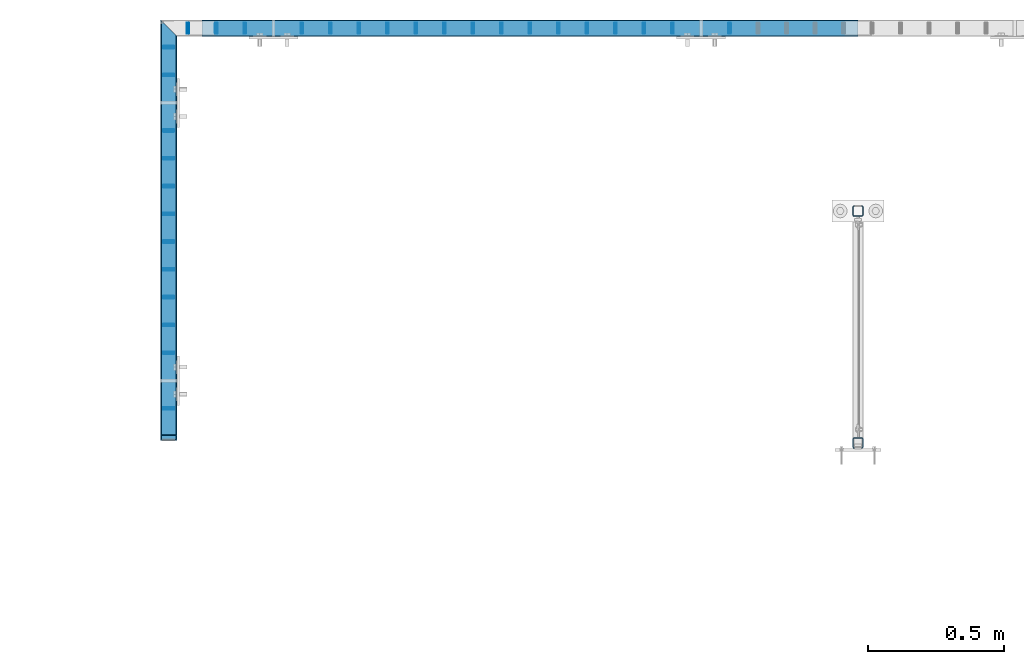
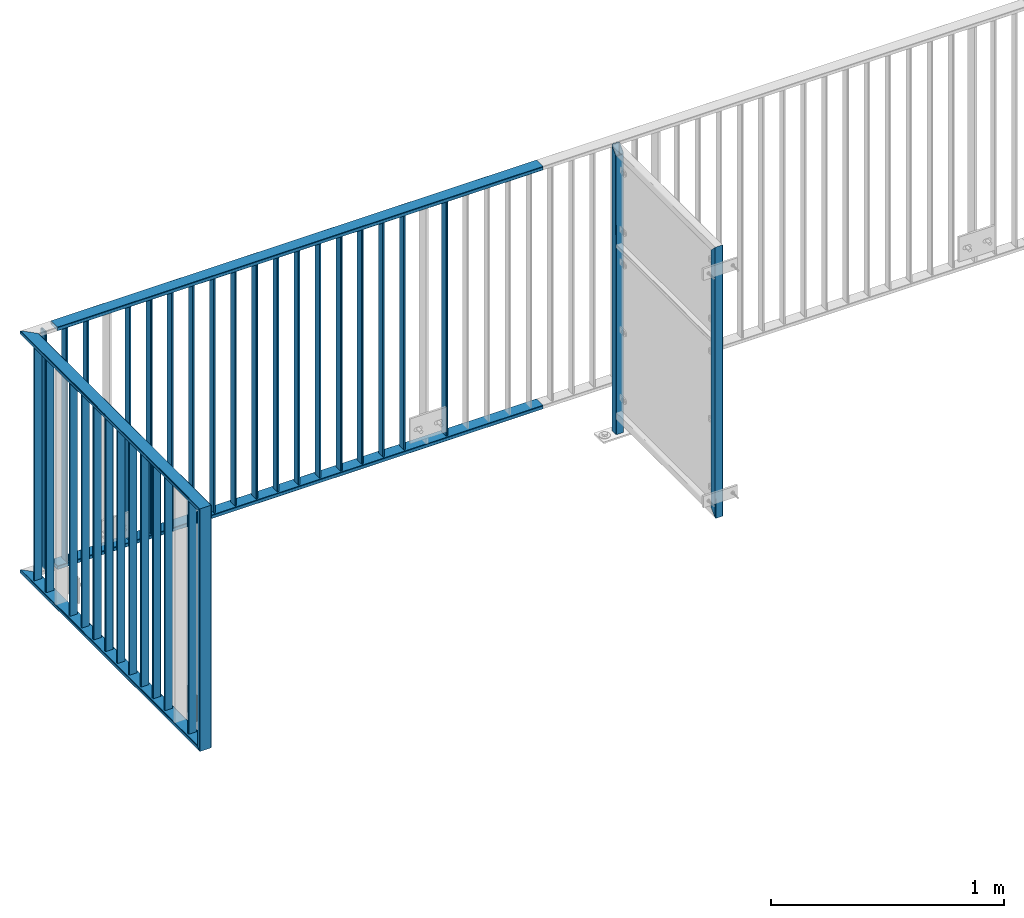
# One storey, part 11 of 156: 37 beams, 3 elements without a shape of their own.
"""IFC2X3 building model written with IfcOpenShell, lengths in millimetres."""

from ifc_helpers import new_model, si_unit, frame, origin_with_axes, origin_2d_with_axis, place, context, subcontext, project, spatial, hollow_rectangle, extrude, clip, halfspace, material, type_object, element, aggregate, save


model = new_model("IFC2X3")

# Units and contexts
model_context = context("Model", 3, precision=1e-05, world=origin_with_axes())
body_context = subcontext(model_context, "Body", "Model", "MODEL_VIEW")
ifc_project = project(units=[si_unit("LENGTHUNIT", "METRE", prefix="MILLI"), si_unit("AREAUNIT", "SQUARE_METRE"), si_unit("VOLUMEUNIT", "CUBIC_METRE"), si_unit("MASSUNIT", "GRAM", prefix="KILO"), si_unit("TIMEUNIT", "SECOND"), si_unit("PLANEANGLEUNIT", "RADIAN"), si_unit("SOLIDANGLEUNIT", "STERADIAN"), si_unit("THERMODYNAMICTEMPERATUREUNIT", "DEGREE_CELSIUS"), si_unit("LUMINOUSINTENSITYUNIT", "LUMEN")], contexts=[model_context])

# Site, building, storey
site_placement = place(None, origin_with_axes())
site = spatial("IfcSite", under=ifc_project, at=site_placement, CompositionType="ELEMENT")
building_placement = place(site_placement, origin_with_axes())
building = spatial("IfcBuilding", under=site, at=building_placement, Name="Undefined", CompositionType="ELEMENT")
storey_placement = place(building_placement, origin_with_axes())
storey = spatial("IfcBuildingStorey", under=building, at=storey_placement, Name="Undefined", CompositionType="ELEMENT", Elevation=0.0)

# Assembly, beam
assembly_1_placement = place(storey_placement, origin_with_axes())
assembly_1 = element("IfcElementAssembly", 1, at=assembly_1_placement, inside=storey, AssemblyPlace="NOTDEFINED", PredefinedType="RIGID_FRAME")
ifc_material = material(Name="STEEL/S235JR")
beam_type_1 = type_object("IfcBeamType", Name="K60/20/2", PredefinedType="NOTDEFINED")
beam_1_placement = place(assembly_1_placement, frame((14799.9535961914, 24057.9916132584, 2740.0), z_axis=(0.0, -1.0, 0.0), x_axis=(-1.0, 0.0, 0.0)))
beam_1 = element("IfcBeam", 2, at=beam_1_placement, type_object=beam_type_1, material=ifc_material, ObjectType="K60/20/2", context=body_context, shape_type="SweptSolid", body=[
    extrude(hollow_rectangle(XDim=20.0, YDim=60.0, WallThickness=2.0, InnerFilletRadius=2.0, OuterFilletRadius=4.0, at=origin_2d_with_axis()), frame((2402.81, 0.0, 0.0), z_axis=(-1.0, 0.0, 0.0), x_axis=(0.0, -1.0, 0.0)), (0.0, 0.0, 1.0), 2402.81),
])

# Assembly, beams
assembly_2_placement = place(storey_placement, origin_with_axes())
assembly_2 = element("IfcElementAssembly", 3, at=assembly_2_placement, inside=storey, AssemblyPlace="NOTDEFINED", PredefinedType="RIGID_FRAME")
beam_2_placement = place(assembly_2_placement, frame((12275.0005187988, 22558.0012658527, 4000.0), z_axis=(1.0, 0.0, 0.0), x_axis=(0.0, 0.0, -1.0)))
beam_2 = element("IfcBeam", 4, at=beam_2_placement, type_object=beam_type_1, material=ifc_material, ObjectType="K60/20/2", context=body_context, shape_type="Clipping", body=[
    clip(clip(extrude(hollow_rectangle(XDim=20.0, YDim=60.0, WallThickness=2.0, InnerFilletRadius=2.0, OuterFilletRadius=4.0, at=origin_2d_with_axis()), frame((1280.2, 0.0, 0.0), z_axis=(-1.0, 0.0, 0.0), x_axis=(0.0, -1.0, 0.0)), (0.0, 0.0, 1.0), 1290.4), halfspace(frame((1270.0, -10.0, 0.0), z_axis=(0.707106781186548, 0.707106781186548, 0.0), x_axis=(0.0, 0.0, 1.0)), False)), halfspace(frame((20.0, 10.0, 0.0), z_axis=(-0.707106781186548, 0.707106781186548, 0.0), x_axis=(0.0, 0.0, 1.0)), False)),
])
beam_3_placement = place(assembly_2_placement, frame((12274.9983520508, 24031.4403835157, 2740.0), z_axis=(1.0, 0.0, 0.0), x_axis=(0.0, -1.0, 0.0)))
beam_3 = element("IfcBeam", 5, at=beam_3_placement, type_object=beam_type_1, material=ifc_material, ObjectType="K60/20/2", context=body_context, shape_type="Clipping", body=[
    clip(clip(extrude(hollow_rectangle(XDim=20.0, YDim=60.0, WallThickness=2.0, InnerFilletRadius=2.0, OuterFilletRadius=4.0, at=origin_2d_with_axis()), frame((1513.83911766303, 0.0, 0.0), z_axis=(-1.0, 0.0, 0.0), x_axis=(0.0, -1.0, 0.0)), (0.0, 0.0, 1.0), 1580.79), halfspace(frame((1483.43911766303, 10.0, 0.002166748046875), z_axis=(-0.707106781186548, 0.707106781186548, 0.0), x_axis=(0.0, 0.0, 1.0)), True)), halfspace(frame((3.44877025730966, 0.0, 30.0), z_axis=(-0.707106781186548, 0.0, 0.707106781186548), x_axis=(0.0, -1.0, 0.0)), False)),
])

# Beam
beam_4_placement = place(assembly_1_placement, frame((14799.9535961914, 24057.9916132584, 3990.0), z_axis=(0.0, -1.0, 0.0), x_axis=(-1.0, 0.0, 0.0)))
beam_4 = element("IfcBeam", 6, at=beam_4_placement, type_object=beam_type_1, material=ifc_material, ObjectType="K60/20/2", context=body_context, shape_type="SweptSolid", body=[
    extrude(hollow_rectangle(XDim=20.0, YDim=60.0, WallThickness=2.0, InnerFilletRadius=2.0, OuterFilletRadius=4.0, at=origin_2d_with_axis()), frame((2402.81, 0.0, 0.0), z_axis=(-1.0, 0.0, 0.0), x_axis=(0.0, -1.0, 0.0)), (0.0, 0.0, 1.0), 2402.81),
])

beam_5_placement = place(assembly_2_placement, frame((12274.9983520508, 24031.4403835157, 3990.0), z_axis=(1.0, 0.0, 0.0), x_axis=(0.0, -1.0, 0.0)))
beam_5 = element("IfcBeam", 7, at=beam_5_placement, type_object=beam_type_1, material=ifc_material, ObjectType="K60/20/2", context=body_context, shape_type="Clipping", body=[
    clip(clip(extrude(hollow_rectangle(XDim=20.0, YDim=60.0, WallThickness=2.0, InnerFilletRadius=2.0, OuterFilletRadius=4.0, at=origin_2d_with_axis()), frame((1513.83911766303, 0.0, 0.0), z_axis=(-1.0, 0.0, 0.0), x_axis=(0.0, -1.0, 0.0)), (0.0, 0.0, 1.0), 1580.79), halfspace(frame((1463.43911766303, 10.0, 0.002166748046875), z_axis=(-0.707106781186548, -0.707106781186548, 0.0), x_axis=(0.0, 0.0, 1.0)), True)), halfspace(frame((-56.5512297426903, 0.0, -30.0), z_axis=(0.707106781186548, 0.0, -0.707106781186548), x_axis=(0.0, -1.0, 0.0)), True)),
])

beam_type_2 = type_object("IfcBeamType", Name="K40/10/1.5", PredefinedType="NOTDEFINED")
beam_6_placement = place(assembly_2_placement, frame((12274.9983597497, 22664.8503835168, 3980.00000000003), z_axis=(1.0, 0.0, 0.0), x_axis=(0.0, 0.0, -1.0)))
beam_6 = element("IfcBeam", 8, at=beam_6_placement, type_object=beam_type_2, material=ifc_material, ObjectType="K40/10/1.5", context=body_context, shape_type="Clipping", body=[
    clip(clip(extrude(hollow_rectangle(XDim=10.0, YDim=40.0, WallThickness=1.5, InnerFilletRadius=1.5, OuterFilletRadius=3.0, at=origin_2d_with_axis()), frame((1237.00000000003, 0.0, 0.0), z_axis=(-1.0, 0.0, 0.0), x_axis=(0.0, -1.0, 0.0)), (0.0, 0.0, 1.0), 1244.0), halfspace(frame((1237.00000000003, 3.90376720472705, 47.0154897941684), z_axis=(1.0, 0.0, 0.0), x_axis=(0.0, -0.761952806119621, -0.647632551101653)), False)), halfspace(frame((-6.99999999997453, -3.90376720472705, 47.0154897941757), z_axis=(-1.0, 0.0, 0.0), x_axis=(0.0, 0.761952806119621, -0.647632551101653)), False)),
])

beam_7_placement = place(assembly_2_placement, frame((12274.9983597497, 22868.4103835168, 3980.00000000003), z_axis=(1.0, 0.0, 0.0), x_axis=(0.0, 0.0, -1.0)))
beam_7 = element("IfcBeam", 9, at=beam_7_placement, type_object=beam_type_2, material=ifc_material, ObjectType="K40/10/1.5", context=body_context, shape_type="Clipping", body=[
    clip(clip(extrude(hollow_rectangle(XDim=10.0, YDim=40.0, WallThickness=1.5, InnerFilletRadius=1.5, OuterFilletRadius=3.0, at=origin_2d_with_axis()), frame((1237.00000000003, 0.0, 0.0), z_axis=(-1.0, 0.0, 0.0), x_axis=(0.0, -1.0, 0.0)), (0.0, 0.0, 1.0), 1244.0), halfspace(frame((1237.00000000003, 3.90376720472705, 47.0154897941684), z_axis=(1.0, 0.0, 0.0), x_axis=(0.0, -0.761952806119621, -0.647632551101653)), False)), halfspace(frame((-6.99999999997453, -3.90376720472705, 47.0154897941757), z_axis=(-1.0, 0.0, 0.0), x_axis=(0.0, 0.761952806119621, -0.647632551101653)), False)),
])

beam_8_placement = place(assembly_2_placement, frame((12274.9983597497, 22970.1903835168, 3980.00000000003), z_axis=(1.0, 0.0, 0.0), x_axis=(0.0, 0.0, -1.0)))
beam_8 = element("IfcBeam", 10, at=beam_8_placement, type_object=beam_type_2, material=ifc_material, ObjectType="K40/10/1.5", context=body_context, shape_type="Clipping", body=[
    clip(clip(extrude(hollow_rectangle(XDim=10.0, YDim=40.0, WallThickness=1.5, InnerFilletRadius=1.5, OuterFilletRadius=3.0, at=origin_2d_with_axis()), frame((1237.00000000003, 0.0, 0.0), z_axis=(-1.0, 0.0, 0.0), x_axis=(0.0, -1.0, 0.0)), (0.0, 0.0, 1.0), 1244.0), halfspace(frame((1237.00000000003, 3.90376720472705, 47.0154897941684), z_axis=(1.0, 0.0, 0.0), x_axis=(0.0, -0.761952806119621, -0.647632551101653)), False)), halfspace(frame((-6.99999999997453, -3.90376720472705, 47.0154897941757), z_axis=(-1.0, 0.0, 0.0), x_axis=(0.0, 0.761952806119621, -0.647632551101653)), False)),
])

beam_9_placement = place(assembly_2_placement, frame((12274.9983597497, 23071.9703835168, 3980.00000000003), z_axis=(1.0, 0.0, 0.0), x_axis=(0.0, 0.0, -1.0)))
beam_9 = element("IfcBeam", 11, at=beam_9_placement, type_object=beam_type_2, material=ifc_material, ObjectType="K40/10/1.5", context=body_context, shape_type="Clipping", body=[
    clip(clip(extrude(hollow_rectangle(XDim=10.0, YDim=40.0, WallThickness=1.5, InnerFilletRadius=1.5, OuterFilletRadius=3.0, at=origin_2d_with_axis()), frame((1237.00000000003, 0.0, 0.0), z_axis=(-1.0, 0.0, 0.0), x_axis=(0.0, -1.0, 0.0)), (0.0, 0.0, 1.0), 1244.0), halfspace(frame((1237.00000000003, 3.90376720472705, 47.0154897941684), z_axis=(1.0, 0.0, 0.0), x_axis=(0.0, -0.761952806119621, -0.647632551101653)), False)), halfspace(frame((-6.99999999997453, -3.90376720472705, 47.0154897941757), z_axis=(-1.0, 0.0, 0.0), x_axis=(0.0, 0.761952806119621, -0.647632551101653)), False)),
])

beam_10_placement = place(assembly_2_placement, frame((12274.9983597497, 23173.7503835168, 3980.00000000003), z_axis=(1.0, 0.0, 0.0), x_axis=(0.0, 0.0, -1.0)))
beam_10 = element("IfcBeam", 12, at=beam_10_placement, type_object=beam_type_2, material=ifc_material, ObjectType="K40/10/1.5", context=body_context, shape_type="Clipping", body=[
    clip(clip(extrude(hollow_rectangle(XDim=10.0, YDim=40.0, WallThickness=1.5, InnerFilletRadius=1.5, OuterFilletRadius=3.0, at=origin_2d_with_axis()), frame((1237.00000000003, 0.0, 0.0), z_axis=(-1.0, 0.0, 0.0), x_axis=(0.0, -1.0, 0.0)), (0.0, 0.0, 1.0), 1244.0), halfspace(frame((1237.00000000003, 3.90376720472705, 47.0154897941684), z_axis=(1.0, 0.0, 0.0), x_axis=(0.0, -0.761952806119621, -0.647632551101653)), False)), halfspace(frame((-6.99999999997453, -3.90376720472705, 47.0154897941757), z_axis=(-1.0, 0.0, 0.0), x_axis=(0.0, 0.761952806119621, -0.647632551101653)), False)),
])

beam_11_placement = place(assembly_2_placement, frame((12274.9983597497, 23275.5303835168, 3980.00000000003), z_axis=(1.0, 0.0, 0.0), x_axis=(0.0, 0.0, -1.0)))
beam_11 = element("IfcBeam", 13, at=beam_11_placement, type_object=beam_type_2, material=ifc_material, ObjectType="K40/10/1.5", context=body_context, shape_type="Clipping", body=[
    clip(clip(extrude(hollow_rectangle(XDim=10.0, YDim=40.0, WallThickness=1.5, InnerFilletRadius=1.5, OuterFilletRadius=3.0, at=origin_2d_with_axis()), frame((1237.00000000003, 0.0, 0.0), z_axis=(-1.0, 0.0, 0.0), x_axis=(0.0, -1.0, 0.0)), (0.0, 0.0, 1.0), 1244.0), halfspace(frame((1237.00000000003, 3.90376720472705, 47.0154897941684), z_axis=(1.0, 0.0, 0.0), x_axis=(0.0, -0.761952806119621, -0.647632551101653)), False)), halfspace(frame((-6.99999999997453, -3.90376720472705, 47.0154897941757), z_axis=(-1.0, 0.0, 0.0), x_axis=(0.0, 0.761952806119621, -0.647632551101653)), False)),
])

beam_12_placement = place(assembly_2_placement, frame((12274.9983597497, 23377.3103835168, 3980.00000000003), z_axis=(1.0, 0.0, 0.0), x_axis=(0.0, 0.0, -1.0)))
beam_12 = element("IfcBeam", 14, at=beam_12_placement, type_object=beam_type_2, material=ifc_material, ObjectType="K40/10/1.5", context=body_context, shape_type="Clipping", body=[
    clip(clip(extrude(hollow_rectangle(XDim=10.0, YDim=40.0, WallThickness=1.5, InnerFilletRadius=1.5, OuterFilletRadius=3.0, at=origin_2d_with_axis()), frame((1237.00000000003, 0.0, 0.0), z_axis=(-1.0, 0.0, 0.0), x_axis=(0.0, -1.0, 0.0)), (0.0, 0.0, 1.0), 1244.0), halfspace(frame((1237.00000000003, 3.90376720472705, 47.0154897941684), z_axis=(1.0, 0.0, 0.0), x_axis=(0.0, -0.761952806119621, -0.647632551101653)), False)), halfspace(frame((-6.99999999997453, -3.90376720472705, 47.0154897941757), z_axis=(-1.0, 0.0, 0.0), x_axis=(0.0, 0.761952806119621, -0.647632551101653)), False)),
])

beam_13_placement = place(assembly_2_placement, frame((12274.9983597497, 23479.0903835168, 3980.00000000003), z_axis=(1.0, 0.0, 0.0), x_axis=(0.0, 0.0, -1.0)))
beam_13 = element("IfcBeam", 15, at=beam_13_placement, type_object=beam_type_2, material=ifc_material, ObjectType="K40/10/1.5", context=body_context, shape_type="Clipping", body=[
    clip(clip(extrude(hollow_rectangle(XDim=10.0, YDim=40.0, WallThickness=1.5, InnerFilletRadius=1.5, OuterFilletRadius=3.0, at=origin_2d_with_axis()), frame((1237.00000000003, 0.0, 0.0), z_axis=(-1.0, 0.0, 0.0), x_axis=(0.0, -1.0, 0.0)), (0.0, 0.0, 1.0), 1244.0), halfspace(frame((1237.00000000003, 3.90376720472705, 47.0154897941684), z_axis=(1.0, 0.0, 0.0), x_axis=(0.0, -0.761952806119621, -0.647632551101653)), False)), halfspace(frame((-6.99999999997453, -3.90376720472705, 47.0154897941757), z_axis=(-1.0, 0.0, 0.0), x_axis=(0.0, 0.761952806119621, -0.647632551101653)), False)),
])

beam_14_placement = place(assembly_2_placement, frame((12274.9983597497, 23580.8703835168, 3980.00000000003), z_axis=(1.0, 0.0, 0.0), x_axis=(0.0, 0.0, -1.0)))
beam_14 = element("IfcBeam", 16, at=beam_14_placement, type_object=beam_type_2, material=ifc_material, ObjectType="K40/10/1.5", context=body_context, shape_type="Clipping", body=[
    clip(clip(extrude(hollow_rectangle(XDim=10.0, YDim=40.0, WallThickness=1.5, InnerFilletRadius=1.5, OuterFilletRadius=3.0, at=origin_2d_with_axis()), frame((1237.00000000003, 0.0, 0.0), z_axis=(-1.0, 0.0, 0.0), x_axis=(0.0, -1.0, 0.0)), (0.0, 0.0, 1.0), 1244.0), halfspace(frame((1237.00000000003, 3.90376720472705, 47.0154897941684), z_axis=(1.0, 0.0, 0.0), x_axis=(0.0, -0.761952806119621, -0.647632551101653)), False)), halfspace(frame((-6.99999999997453, -3.90376720472705, 47.0154897941757), z_axis=(-1.0, 0.0, 0.0), x_axis=(0.0, 0.761952806119621, -0.647632551101653)), False)),
])

beam_15_placement = place(assembly_2_placement, frame((12274.9983597497, 23682.6503835168, 3980.00000000003), z_axis=(1.0, 0.0, 0.0), x_axis=(0.0, 0.0, -1.0)))
beam_15 = element("IfcBeam", 17, at=beam_15_placement, type_object=beam_type_2, material=ifc_material, ObjectType="K40/10/1.5", context=body_context, shape_type="Clipping", body=[
    clip(clip(extrude(hollow_rectangle(XDim=10.0, YDim=40.0, WallThickness=1.5, InnerFilletRadius=1.5, OuterFilletRadius=3.0, at=origin_2d_with_axis()), frame((1237.00000000003, 0.0, 0.0), z_axis=(-1.0, 0.0, 0.0), x_axis=(0.0, -1.0, 0.0)), (0.0, 0.0, 1.0), 1244.0), halfspace(frame((1237.00000000003, 3.90376720472705, 47.0154897941684), z_axis=(1.0, 0.0, 0.0), x_axis=(0.0, -0.761952806119621, -0.647632551101653)), False)), halfspace(frame((-6.99999999997453, -3.90376720472705, 47.0154897941757), z_axis=(-1.0, 0.0, 0.0), x_axis=(0.0, 0.761952806119621, -0.647632551101653)), False)),
])

beam_16_placement = place(assembly_1_placement, frame((12553.8485961914, 24057.9916132584, 3980.00000000003), z_axis=(0.0, -1.0, 0.0), x_axis=(0.0, 0.0, -1.0)))
beam_16 = element("IfcBeam", 18, at=beam_16_placement, type_object=beam_type_2, material=ifc_material, ObjectType="K40/10/1.5", context=body_context, shape_type="Clipping", body=[
    clip(extrude(hollow_rectangle(XDim=10.0, YDim=40.0, WallThickness=1.5, InnerFilletRadius=1.5, OuterFilletRadius=3.0, at=origin_2d_with_axis()), frame((1230.0, 0.0, 0.0), z_axis=(-1.0, 0.0, 0.0), x_axis=(0.0, -1.0, 0.0)), (0.0, 0.0, 1.0), 1230.0), halfspace(frame((-6.99999999997453, -4.34248751950508, 47.3810900558092), z_axis=(-1.0, 0.0, 0.0), x_axis=(0.0, 0.7683548141934, -0.640024124159258)), False)),
])

beam_17_placement = place(assembly_1_placement, frame((14120.8985961914, 24057.9916132584, 3980.00000000003), z_axis=(0.0, -1.0, 0.0), x_axis=(0.0, 0.0, -1.0)))
beam_17 = element("IfcBeam", 19, at=beam_17_placement, type_object=beam_type_2, material=ifc_material, ObjectType="K40/10/1.5", context=body_context, shape_type="Clipping", body=[
    clip(clip(extrude(hollow_rectangle(XDim=10.0, YDim=40.0, WallThickness=1.5, InnerFilletRadius=1.5, OuterFilletRadius=3.0, at=origin_2d_with_axis()), frame((1237.00000000003, 0.0, 0.0), z_axis=(-1.0, 0.0, 0.0), x_axis=(0.0, -1.0, 0.0)), (0.0, 0.0, 1.0), 1244.0), halfspace(frame((1237.00000000003, 4.34248751949781, 47.3810900558092), z_axis=(1.0, 0.0, 0.0), x_axis=(0.0, -0.768354814194188, -0.640024124158313)), False)), halfspace(frame((-6.99999999997453, -4.34248751950508, 47.3810900558092), z_axis=(-1.0, 0.0, 0.0), x_axis=(0.0, 0.7683548141934, -0.640024124159258)), False)),
])

beam_18_placement = place(assembly_1_placement, frame((12449.3785961914, 24057.9916132584, 3980.00000000003), z_axis=(0.0, -1.0, 0.0), x_axis=(0.0, 0.0, -1.0)))
beam_18 = element("IfcBeam", 20, at=beam_18_placement, type_object=beam_type_2, material=ifc_material, ObjectType="K40/10/1.5", context=body_context, shape_type="Clipping", body=[
    clip(clip(extrude(hollow_rectangle(XDim=10.0, YDim=40.0, WallThickness=1.5, InnerFilletRadius=1.5, OuterFilletRadius=3.0, at=origin_2d_with_axis()), frame((1237.00000000003, 0.0, 0.0), z_axis=(-1.0, 0.0, 0.0), x_axis=(0.0, -1.0, 0.0)), (0.0, 0.0, 1.0), 1244.0), halfspace(frame((1237.00000000003, 4.34248751949781, 47.3810900558092), z_axis=(1.0, 0.0, 0.0), x_axis=(0.0, -0.763991285051099, -0.645226562043109)), False)), halfspace(frame((-6.99999999997453, -4.34248751950508, 47.3810900558092), z_axis=(-1.0, 0.0, 0.0), x_axis=(0.0, 0.763991285051099, -0.645226562043109)), False)),
])

beam_19_placement = place(assembly_1_placement, frame((12762.7885961914, 24057.9916132584, 3980.00000000003), z_axis=(0.0, -1.0, 0.0), x_axis=(0.0, 0.0, -1.0)))
beam_19 = element("IfcBeam", 21, at=beam_19_placement, type_object=beam_type_2, material=ifc_material, ObjectType="K40/10/1.5", context=body_context, shape_type="Clipping", body=[
    clip(clip(extrude(hollow_rectangle(XDim=10.0, YDim=40.0, WallThickness=1.5, InnerFilletRadius=1.5, OuterFilletRadius=3.0, at=origin_2d_with_axis()), frame((1237.00000000003, 0.0, 0.0), z_axis=(-1.0, 0.0, 0.0), x_axis=(0.0, -1.0, 0.0)), (0.0, 0.0, 1.0), 1244.0), halfspace(frame((1237.00000000003, 4.34248751949781, 47.3810900558092), z_axis=(1.0, 0.0, 0.0), x_axis=(0.0, -0.768354814194188, -0.640024124158313)), False)), halfspace(frame((-6.99999999997453, -4.34248751950508, 47.3810900558092), z_axis=(-1.0, 0.0, 0.0), x_axis=(0.0, 0.7683548141934, -0.640024124159258)), False)),
])

beam_20_placement = place(assembly_1_placement, frame((12867.2585961914, 24057.9916132584, 3980.00000000003), z_axis=(0.0, -1.0, 0.0), x_axis=(0.0, 0.0, -1.0)))
beam_20 = element("IfcBeam", 22, at=beam_20_placement, type_object=beam_type_2, material=ifc_material, ObjectType="K40/10/1.5", context=body_context, shape_type="Clipping", body=[
    clip(clip(extrude(hollow_rectangle(XDim=10.0, YDim=40.0, WallThickness=1.5, InnerFilletRadius=1.5, OuterFilletRadius=3.0, at=origin_2d_with_axis()), frame((1237.00000000003, 0.0, 0.0), z_axis=(-1.0, 0.0, 0.0), x_axis=(0.0, -1.0, 0.0)), (0.0, 0.0, 1.0), 1244.0), halfspace(frame((1237.00000000003, 4.34248751949781, 47.3810900558092), z_axis=(1.0, 0.0, 0.0), x_axis=(0.0, -0.768354814194188, -0.640024124158313)), False)), halfspace(frame((-6.99999999997453, -4.34248751950508, 47.3810900558092), z_axis=(-1.0, 0.0, 0.0), x_axis=(0.0, 0.7683548141934, -0.640024124159258)), False)),
])

beam_21_placement = place(assembly_1_placement, frame((12971.7285961914, 24057.9916132584, 3980.00000000003), z_axis=(0.0, -1.0, 0.0), x_axis=(0.0, 0.0, -1.0)))
beam_21 = element("IfcBeam", 23, at=beam_21_placement, type_object=beam_type_2, material=ifc_material, ObjectType="K40/10/1.5", context=body_context, shape_type="Clipping", body=[
    clip(clip(extrude(hollow_rectangle(XDim=10.0, YDim=40.0, WallThickness=1.5, InnerFilletRadius=1.5, OuterFilletRadius=3.0, at=origin_2d_with_axis()), frame((1237.00000000003, 0.0, 0.0), z_axis=(-1.0, 0.0, 0.0), x_axis=(0.0, -1.0, 0.0)), (0.0, 0.0, 1.0), 1244.0), halfspace(frame((1237.00000000003, 4.34248751949781, 47.3810900558092), z_axis=(1.0, 0.0, 0.0), x_axis=(0.0, -0.768354814194188, -0.640024124158313)), False)), halfspace(frame((-6.99999999997453, -4.34248751950508, 47.3810900558092), z_axis=(-1.0, 0.0, 0.0), x_axis=(0.0, 0.7683548141934, -0.640024124159258)), False)),
])

beam_22_placement = place(assembly_1_placement, frame((13076.1985961914, 24057.9916132584, 3980.00000000003), z_axis=(0.0, -1.0, 0.0), x_axis=(0.0, 0.0, -1.0)))
beam_22 = element("IfcBeam", 24, at=beam_22_placement, type_object=beam_type_2, material=ifc_material, ObjectType="K40/10/1.5", context=body_context, shape_type="Clipping", body=[
    clip(clip(extrude(hollow_rectangle(XDim=10.0, YDim=40.0, WallThickness=1.5, InnerFilletRadius=1.5, OuterFilletRadius=3.0, at=origin_2d_with_axis()), frame((1237.00000000003, 0.0, 0.0), z_axis=(-1.0, 0.0, 0.0), x_axis=(0.0, -1.0, 0.0)), (0.0, 0.0, 1.0), 1244.0), halfspace(frame((1237.00000000003, 4.34248751949781, 47.3810900558092), z_axis=(1.0, 0.0, 0.0), x_axis=(0.0, -0.768354814194188, -0.640024124158313)), False)), halfspace(frame((-6.99999999997453, -4.34248751950508, 47.3810900558092), z_axis=(-1.0, 0.0, 0.0), x_axis=(0.0, 0.7683548141934, -0.640024124159258)), False)),
])

beam_23_placement = place(assembly_1_placement, frame((13180.6685961914, 24057.9916132584, 3980.00000000003), z_axis=(0.0, -1.0, 0.0), x_axis=(0.0, 0.0, -1.0)))
beam_23 = element("IfcBeam", 25, at=beam_23_placement, type_object=beam_type_2, material=ifc_material, ObjectType="K40/10/1.5", context=body_context, shape_type="Clipping", body=[
    clip(clip(extrude(hollow_rectangle(XDim=10.0, YDim=40.0, WallThickness=1.5, InnerFilletRadius=1.5, OuterFilletRadius=3.0, at=origin_2d_with_axis()), frame((1237.00000000003, 0.0, 0.0), z_axis=(-1.0, 0.0, 0.0), x_axis=(0.0, -1.0, 0.0)), (0.0, 0.0, 1.0), 1244.0), halfspace(frame((1237.00000000003, 4.34248751949781, 47.3810900558092), z_axis=(1.0, 0.0, 0.0), x_axis=(0.0, -0.768354814194188, -0.640024124158313)), False)), halfspace(frame((-6.99999999997453, -4.34248751950508, 47.3810900558092), z_axis=(-1.0, 0.0, 0.0), x_axis=(0.0, 0.7683548141934, -0.640024124159258)), False)),
])

beam_24_placement = place(assembly_1_placement, frame((13285.1385961914, 24057.9916132584, 3980.00000000003), z_axis=(0.0, -1.0, 0.0), x_axis=(0.0, 0.0, -1.0)))
beam_24 = element("IfcBeam", 26, at=beam_24_placement, type_object=beam_type_2, material=ifc_material, ObjectType="K40/10/1.5", context=body_context, shape_type="Clipping", body=[
    clip(clip(extrude(hollow_rectangle(XDim=10.0, YDim=40.0, WallThickness=1.5, InnerFilletRadius=1.5, OuterFilletRadius=3.0, at=origin_2d_with_axis()), frame((1237.00000000003, 0.0, 0.0), z_axis=(-1.0, 0.0, 0.0), x_axis=(0.0, -1.0, 0.0)), (0.0, 0.0, 1.0), 1244.0), halfspace(frame((1237.00000000003, 4.34248751949781, 47.3810900558092), z_axis=(1.0, 0.0, 0.0), x_axis=(0.0, -0.768354814194188, -0.640024124158313)), False)), halfspace(frame((-6.99999999997453, -4.34248751950508, 47.3810900558092), z_axis=(-1.0, 0.0, 0.0), x_axis=(0.0, 0.7683548141934, -0.640024124159258)), False)),
])

beam_25_placement = place(assembly_1_placement, frame((13389.6085961914, 24057.9916132584, 3980.00000000003), z_axis=(0.0, -1.0, 0.0), x_axis=(0.0, 0.0, -1.0)))
beam_25 = element("IfcBeam", 27, at=beam_25_placement, type_object=beam_type_2, material=ifc_material, ObjectType="K40/10/1.5", context=body_context, shape_type="Clipping", body=[
    clip(clip(extrude(hollow_rectangle(XDim=10.0, YDim=40.0, WallThickness=1.5, InnerFilletRadius=1.5, OuterFilletRadius=3.0, at=origin_2d_with_axis()), frame((1237.00000000003, 0.0, 0.0), z_axis=(-1.0, 0.0, 0.0), x_axis=(0.0, -1.0, 0.0)), (0.0, 0.0, 1.0), 1244.0), halfspace(frame((1237.00000000003, 4.34248751949781, 47.3810900558092), z_axis=(1.0, 0.0, 0.0), x_axis=(0.0, -0.768354814194188, -0.640024124158313)), False)), halfspace(frame((-6.99999999997453, -4.34248751950508, 47.3810900558092), z_axis=(-1.0, 0.0, 0.0), x_axis=(0.0, 0.7683548141934, -0.640024124159258)), False)),
])

beam_26_placement = place(assembly_1_placement, frame((13494.0785961914, 24057.9916132584, 3980.00000000003), z_axis=(0.0, -1.0, 0.0), x_axis=(0.0, 0.0, -1.0)))
beam_26 = element("IfcBeam", 28, at=beam_26_placement, type_object=beam_type_2, material=ifc_material, ObjectType="K40/10/1.5", context=body_context, shape_type="Clipping", body=[
    clip(clip(extrude(hollow_rectangle(XDim=10.0, YDim=40.0, WallThickness=1.5, InnerFilletRadius=1.5, OuterFilletRadius=3.0, at=origin_2d_with_axis()), frame((1237.00000000003, 0.0, 0.0), z_axis=(-1.0, 0.0, 0.0), x_axis=(0.0, -1.0, 0.0)), (0.0, 0.0, 1.0), 1244.0), halfspace(frame((1237.00000000003, 4.34248751949781, 47.3810900558092), z_axis=(1.0, 0.0, 0.0), x_axis=(0.0, -0.768354814194188, -0.640024124158313)), False)), halfspace(frame((-6.99999999997453, -4.34248751950508, 47.3810900558092), z_axis=(-1.0, 0.0, 0.0), x_axis=(0.0, 0.7683548141934, -0.640024124159258)), False)),
])

beam_27_placement = place(assembly_1_placement, frame((13598.5485961914, 24057.9916132584, 3980.00000000003), z_axis=(0.0, -1.0, 0.0), x_axis=(0.0, 0.0, -1.0)))
beam_27 = element("IfcBeam", 29, at=beam_27_placement, type_object=beam_type_2, material=ifc_material, ObjectType="K40/10/1.5", context=body_context, shape_type="Clipping", body=[
    clip(clip(extrude(hollow_rectangle(XDim=10.0, YDim=40.0, WallThickness=1.5, InnerFilletRadius=1.5, OuterFilletRadius=3.0, at=origin_2d_with_axis()), frame((1237.00000000003, 0.0, 0.0), z_axis=(-1.0, 0.0, 0.0), x_axis=(0.0, -1.0, 0.0)), (0.0, 0.0, 1.0), 1244.0), halfspace(frame((1237.00000000003, 4.34248751949781, 47.3810900558092), z_axis=(1.0, 0.0, 0.0), x_axis=(0.0, -0.768354814194188, -0.640024124158313)), False)), halfspace(frame((-6.99999999997453, -4.34248751950508, 47.3810900558092), z_axis=(-1.0, 0.0, 0.0), x_axis=(0.0, 0.7683548141934, -0.640024124159258)), False)),
])

beam_28_placement = place(assembly_1_placement, frame((13703.0185961914, 24057.9916132584, 3980.00000000003), z_axis=(0.0, -1.0, 0.0), x_axis=(0.0, 0.0, -1.0)))
beam_28 = element("IfcBeam", 30, at=beam_28_placement, type_object=beam_type_2, material=ifc_material, ObjectType="K40/10/1.5", context=body_context, shape_type="Clipping", body=[
    clip(clip(extrude(hollow_rectangle(XDim=10.0, YDim=40.0, WallThickness=1.5, InnerFilletRadius=1.5, OuterFilletRadius=3.0, at=origin_2d_with_axis()), frame((1237.00000000003, 0.0, 0.0), z_axis=(-1.0, 0.0, 0.0), x_axis=(0.0, -1.0, 0.0)), (0.0, 0.0, 1.0), 1244.0), halfspace(frame((1237.00000000003, 4.34248751949781, 47.3810900558092), z_axis=(1.0, 0.0, 0.0), x_axis=(0.0, -0.768354814194188, -0.640024124158313)), False)), halfspace(frame((-6.99999999997453, -4.34248751950508, 47.3810900558092), z_axis=(-1.0, 0.0, 0.0), x_axis=(0.0, 0.7683548141934, -0.640024124159258)), False)),
])

beam_29_placement = place(assembly_1_placement, frame((13807.4885961914, 24057.9916132584, 3980.00000000003), z_axis=(0.0, -1.0, 0.0), x_axis=(0.0, 0.0, -1.0)))
beam_29 = element("IfcBeam", 31, at=beam_29_placement, type_object=beam_type_2, material=ifc_material, ObjectType="K40/10/1.5", context=body_context, shape_type="Clipping", body=[
    clip(clip(extrude(hollow_rectangle(XDim=10.0, YDim=40.0, WallThickness=1.5, InnerFilletRadius=1.5, OuterFilletRadius=3.0, at=origin_2d_with_axis()), frame((1237.00000000003, 0.0, 0.0), z_axis=(-1.0, 0.0, 0.0), x_axis=(0.0, -1.0, 0.0)), (0.0, 0.0, 1.0), 1244.0), halfspace(frame((1237.00000000003, 4.34248751949781, 47.3810900558092), z_axis=(1.0, 0.0, 0.0), x_axis=(0.0, -0.768354814194188, -0.640024124158313)), False)), halfspace(frame((-6.99999999997453, -4.34248751950508, 47.3810900558092), z_axis=(-1.0, 0.0, 0.0), x_axis=(0.0, 0.7683548141934, -0.640024124159258)), False)),
])

beam_30_placement = place(assembly_1_placement, frame((13911.9585961914, 24057.9916132584, 3980.00000000003), z_axis=(0.0, -1.0, 0.0), x_axis=(0.0, 0.0, -1.0)))
beam_30 = element("IfcBeam", 32, at=beam_30_placement, type_object=beam_type_2, material=ifc_material, ObjectType="K40/10/1.5", context=body_context, shape_type="Clipping", body=[
    clip(clip(extrude(hollow_rectangle(XDim=10.0, YDim=40.0, WallThickness=1.5, InnerFilletRadius=1.5, OuterFilletRadius=3.0, at=origin_2d_with_axis()), frame((1237.00000000003, 0.0, 0.0), z_axis=(-1.0, 0.0, 0.0), x_axis=(0.0, -1.0, 0.0)), (0.0, 0.0, 1.0), 1244.0), halfspace(frame((1237.00000000003, 4.34248751949781, 47.3810900558092), z_axis=(1.0, 0.0, 0.0), x_axis=(0.0, -0.768354814194188, -0.640024124158313)), False)), halfspace(frame((-6.99999999997453, -4.34248751950508, 47.3810900558092), z_axis=(-1.0, 0.0, 0.0), x_axis=(0.0, 0.7683548141934, -0.640024124159258)), False)),
])

beam_31_placement = place(assembly_1_placement, frame((14016.4285961914, 24057.9916132584, 3980.00000000003), z_axis=(0.0, -1.0, 0.0), x_axis=(0.0, 0.0, -1.0)))
beam_31 = element("IfcBeam", 33, at=beam_31_placement, type_object=beam_type_2, material=ifc_material, ObjectType="K40/10/1.5", context=body_context, shape_type="Clipping", body=[
    clip(clip(extrude(hollow_rectangle(XDim=10.0, YDim=40.0, WallThickness=1.5, InnerFilletRadius=1.5, OuterFilletRadius=3.0, at=origin_2d_with_axis()), frame((1237.00000000003, 0.0, 0.0), z_axis=(-1.0, 0.0, 0.0), x_axis=(0.0, -1.0, 0.0)), (0.0, 0.0, 1.0), 1244.0), halfspace(frame((1237.00000000003, 4.34248751949781, 47.3810900558092), z_axis=(1.0, 0.0, 0.0), x_axis=(0.0, -0.768354814194188, -0.640024124158313)), False)), halfspace(frame((-6.99999999997453, -4.34248751950508, 47.3810900558092), z_axis=(-1.0, 0.0, 0.0), x_axis=(0.0, 0.7683548141934, -0.640024124159258)), False)),
])

beam_32_placement = place(assembly_1_placement, frame((14329.8385961914, 24057.9916132584, 3980.00000000003), z_axis=(0.0, -1.0, 0.0), x_axis=(0.0, 0.0, -1.0)))
beam_32 = element("IfcBeam", 34, at=beam_32_placement, type_object=beam_type_2, material=ifc_material, ObjectType="K40/10/1.5", context=body_context, shape_type="Clipping", body=[
    clip(clip(extrude(hollow_rectangle(XDim=10.0, YDim=40.0, WallThickness=1.5, InnerFilletRadius=1.5, OuterFilletRadius=3.0, at=origin_2d_with_axis()), frame((1237.00000000003, 0.0, 0.0), z_axis=(-1.0, 0.0, 0.0), x_axis=(0.0, -1.0, 0.0)), (0.0, 0.0, 1.0), 1244.0), halfspace(frame((1237.00000000003, 4.34248751949781, 47.3810900558092), z_axis=(1.0, 0.0, 0.0), x_axis=(0.0, -0.768354814194188, -0.640024124158313)), False)), halfspace(frame((-6.99999999997453, -4.34248751950508, 47.3810900558092), z_axis=(-1.0, 0.0, 0.0), x_axis=(0.0, 0.7683548141934, -0.640024124159258)), False)),
])

aggregate(assembly_1, [beam_1, beam_16, beam_17, beam_18, beam_19, beam_20, beam_21, beam_22, beam_23, beam_24, beam_25, beam_26, beam_27, beam_28, beam_29, beam_30, beam_31, beam_32, beam_4])

beam_33_placement = place(assembly_2_placement, frame((12274.9983597497, 23886.2103835168, 3980.00000000003), z_axis=(1.0, 0.0, 0.0), x_axis=(0.0, 0.0, -1.0)))
beam_33 = element("IfcBeam", 35, at=beam_33_placement, type_object=beam_type_2, material=ifc_material, ObjectType="K40/10/1.5", context=body_context, shape_type="Clipping", body=[
    clip(clip(extrude(hollow_rectangle(XDim=10.0, YDim=40.0, WallThickness=1.5, InnerFilletRadius=1.5, OuterFilletRadius=3.0, at=origin_2d_with_axis()), frame((1237.00000000003, 0.0, 0.0), z_axis=(-1.0, 0.0, 0.0), x_axis=(0.0, -1.0, 0.0)), (0.0, 0.0, 1.0), 1244.0), halfspace(frame((1237.00000000003, 3.63803898150218, 46.7940496082883), z_axis=(1.0, 0.0, 0.0), x_axis=(0.0, -0.758923924280425, -0.65117929724063)), False)), halfspace(frame((-6.99999999997453, -3.63803898149854, 46.7940496082956), z_axis=(-1.0, 0.0, 0.0), x_axis=(0.0, 0.75892392428044, -0.651179297240612)), False)),
])

beam_34_placement = place(assembly_2_placement, frame((12344.998046875, 24057.9916132584, 3980.00000000003), z_axis=(0.0, -1.0, 0.0), x_axis=(0.0, 0.0, -1.0)))
beam_34 = element("IfcBeam", 36, at=beam_34_placement, type_object=beam_type_2, material=ifc_material, ObjectType="K40/10/1.5", context=body_context, shape_type="Clipping", body=[
    clip(clip(extrude(hollow_rectangle(XDim=10.0, YDim=40.0, WallThickness=1.5, InnerFilletRadius=1.5, OuterFilletRadius=3.0, at=origin_2d_with_axis()), frame((1237.00000000003, 0.0, 0.0), z_axis=(-1.0, 0.0, 0.0), x_axis=(0.0, -1.0, 0.0)), (0.0, 0.0, 1.0), 1244.0), halfspace(frame((1237.00000000003, 4.34248751949781, 47.3810900558092), z_axis=(1.0, 0.0, 0.0), x_axis=(0.0, -0.768354814194188, -0.640024124158313)), False)), halfspace(frame((-6.99999999997453, -4.34248751950508, 47.3810900558092), z_axis=(-1.0, 0.0, 0.0), x_axis=(0.0, 0.7683548141934, -0.640024124159258)), False)),
])

beam_35_placement = place(assembly_2_placement, frame((12274.9983597497, 23987.9903835168, 3980.00000000003), z_axis=(1.0, 0.0, 0.0), x_axis=(0.0, 0.0, -1.0)))
beam_35 = element("IfcBeam", 37, at=beam_35_placement, type_object=beam_type_2, material=ifc_material, ObjectType="K40/10/1.5", context=body_context, shape_type="Clipping", body=[
    clip(clip(extrude(hollow_rectangle(XDim=10.0, YDim=40.0, WallThickness=1.5, InnerFilletRadius=1.5, OuterFilletRadius=3.0, at=origin_2d_with_axis()), frame((1237.00000000003, 0.0, 0.0), z_axis=(-1.0, 0.0, 0.0), x_axis=(0.0, -1.0, 0.0)), (0.0, 0.0, 1.0), 1244.0), halfspace(frame((1237.00000000003, 1.80362172154128, 45.2653685592795), z_axis=(1.0, 0.0, 0.0), x_axis=(0.0, -0.737586551668085, -0.675252603696115)), False)), halfspace(frame((-6.99999999997453, -1.80362172153764, 45.2653685592795), z_axis=(-1.0, 0.0, 0.0), x_axis=(0.0, 0.737586551668074, -0.675252603696127)), False)),
])

aggregate(assembly_2, [beam_6, beam_7, beam_8, beam_9, beam_10, beam_11, beam_12, beam_13, beam_14, beam_15, beam_33, beam_34, beam_2, beam_35, beam_3, beam_5])

# Assembly, beams
assembly_3_placement = place(storey_placement, origin_with_axes())
assembly_3 = element("IfcElementAssembly", 38, at=assembly_3_placement, inside=storey, AssemblyPlace="NOTDEFINED", PredefinedType="RIGID_FRAME")
beam_type_3 = type_object("IfcBeamType", Name="K40/3", PredefinedType="NOTDEFINED")
beam_36_placement = place(assembly_3_placement, frame((14800.0, 23388.0025791195, 4299.99608012897), z_axis=(1.0, 0.0, 0.0), x_axis=(0.0, 0.000195990999960296, -0.999999980793764)))
beam_36 = element("IfcBeam", 39, at=beam_36_placement, type_object=beam_type_3, material=ifc_material, ObjectType="K40/3", context=body_context, shape_type="Clipping", body=[
    clip(clip(extrude(hollow_rectangle(XDim=40.0, YDim=40.0, WallThickness=3.0, InnerFilletRadius=3.0, OuterFilletRadius=6.0, at=origin_2d_with_axis()), frame((1317.21220694614, 0.0, 0.0), z_axis=(-1.0, 0.0, 0.0), x_axis=(0.0, -1.0, 0.0)), (0.0, 0.0, 1.0), 1517.43), halfspace(frame((1297.00033107046, -3.63797880709171e-12, -20.0), z_axis=(-1.0, 0.0, 0.0), x_axis=(0.0, 1.0, 0.0)), True)), halfspace(frame((-200.000003844783, 19.9999999999418, 0.0), z_axis=(0.707176071357089, 0.70703748422552, 0.0), x_axis=(0.0, 0.0, -1.0)), True)),
])
beam_37_placement = place(assembly_3_placement, frame((14800.0, 22538.0010528564, 4299.9999999525), z_axis=(1.0, 0.0, 0.0), x_axis=(0.0, 0.0, -1.0)))
beam_37 = element("IfcBeam", 40, at=beam_37_placement, type_object=beam_type_3, material=ifc_material, ObjectType="K40/3", context=body_context, shape_type="Clipping", body=[
    clip(clip(extrude(hollow_rectangle(XDim=40.0, YDim=40.0, WallThickness=3.0, InnerFilletRadius=3.0, OuterFilletRadius=6.0, at=origin_2d_with_axis()), frame((1240.4, 0.0, 0.0), z_axis=(-1.0, 0.0, 0.0), x_axis=(0.0, -1.0, 0.0)), (0.0, 0.0, 1.0), 1460.8), halfspace(frame((1180.0, 20.0, 0.0), z_axis=(-0.707106781186548, -0.707106781186548, 0.0), x_axis=(0.0, 0.0, 1.0)), True)), halfspace(frame((-200.0, -20.0, 0.0), z_axis=(0.707106781186548, -0.707106781186548, 0.0), x_axis=(0.0, 0.0, 1.0)), True)),
])
aggregate(assembly_3, [beam_36, beam_37])

save(model, "model.ifc")
